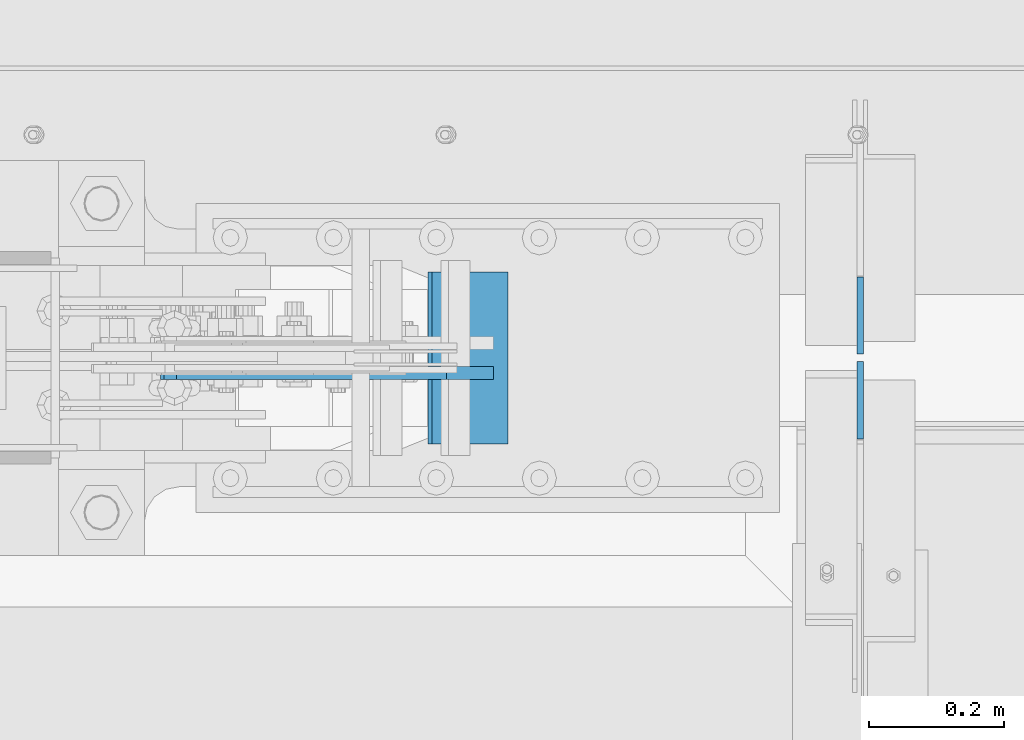
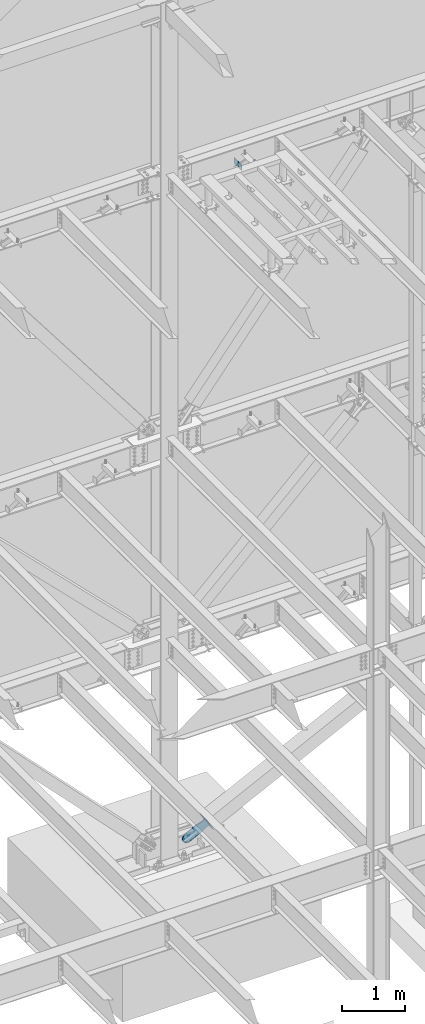
# One storey, part 1074 of 1179: 4 plates, 3 elements without a shape of their own.
"""IFC2X3 building model written with IfcOpenShell, lengths in millimetres."""

from ifc_helpers import new_model, si_unit, frame, origin_with_axes, place, context, subcontext, project, spatial, faceted_brep, material, type_object, element, aggregate, save


model = new_model("IFC2X3")

# Units and contexts
model_context = context("Model", 3, precision=1e-05, world=origin_with_axes())
body_context = subcontext(model_context, "Body", "Model", "MODEL_VIEW")
ifc_project = project(units=[si_unit("LENGTHUNIT", "METRE", prefix="MILLI"), si_unit("AREAUNIT", "SQUARE_METRE"), si_unit("VOLUMEUNIT", "CUBIC_METRE"), si_unit("MASSUNIT", "GRAM", prefix="KILO"), si_unit("TIMEUNIT", "SECOND"), si_unit("PLANEANGLEUNIT", "RADIAN"), si_unit("SOLIDANGLEUNIT", "STERADIAN"), si_unit("THERMODYNAMICTEMPERATUREUNIT", "DEGREE_CELSIUS"), si_unit("LUMINOUSINTENSITYUNIT", "LUMEN")], contexts=[model_context])

# Site, building, storey
site_placement = place(None, origin_with_axes())
site = spatial("IfcSite", under=ifc_project, at=site_placement, CompositionType="ELEMENT")
building_placement = place(site_placement, origin_with_axes())
building = spatial("IfcBuilding", under=site, at=building_placement, Name="Undefined", CompositionType="ELEMENT")
storey_placement = place(building_placement, origin_with_axes())
storey = spatial("IfcBuildingStorey", under=building, at=storey_placement, Name="Undefined", CompositionType="ELEMENT", Elevation=0.0)

# Assembly, plate
assembly_1_placement = place(storey_placement, origin_with_axes())
assembly_1 = element("IfcElementAssembly", 1, at=assembly_1_placement, inside=storey, AssemblyPlace="NOTDEFINED", PredefinedType="RIGID_FRAME")
ifc_material = material(Name="STEEL/A36")
plate_type_1 = type_object("IfcPlateType", PredefinedType="NOTDEFINED")
plate_1_placement = place(assembly_1_placement, frame((9015.15683481444, 41176.575, 58.9959651378661), z_axis=(-0.443172292794208, 0.0, 0.896436455583732), x_axis=(0.896436455583732, 0.0, 0.443172292794209)))
plate_1 = element("IfcPlate", 2, at=plate_1_placement, type_object=plate_type_1, material=ifc_material, context=body_context, shape_type="Brep", body=[
    faceted_brep([(0.0, -9.52499999999964, 0.0), (-101.599999999631, -9.52500000000146, -17.6403935121948), (-101.599999999631, 9.52500000000146, -17.6403935121948), (0.0, 9.52499999999964, 0.0), (-320.279297669141, -9.52500000000146, -17.6403935121907), (-320.279297669141, 9.52500000000146, -17.6403935121907), (-357.337405134735, -9.52500000000146, -10.2690776255863), (-357.337405134735, 9.52500000000146, -10.2690776255863), (-388.753751671267, -9.52500000000146, 10.7226540116294), (-388.753751671267, 9.52500000000146, 10.7226540116294), (-409.745483308434, -9.52500000000146, 42.1390005482076), (-409.745483308434, 9.52500000000146, 42.1390005482076), (-417.116799194993, -9.52500000000146, 79.1971049621179), (-417.116799194993, 9.52500000000146, 79.1971049621179), (-409.745483308381, -9.52500000000146, 116.255212427672), (-409.745483308381, 9.52500000000146, 116.255212427672), (-388.753751671213, -9.52500000000146, 147.671558964167), (-388.753751671213, 9.52500000000146, 147.671558964167), (-357.337405134718, -9.52500000000146, 168.663290601317), (-357.337405134718, 9.52500000000146, 168.663290601317), (-320.279299195261, -9.52500000000146, 176.034606487895), (-320.279299195261, 9.52500000000146, 176.034606487895), (-101.599999999431, -9.52500000000146, 176.034606487892), (-101.599999999431, 9.52500000000146, 176.034606487892), (2.34649633057415e-10, -9.52500000000146, 158.394212975713), (2.34649633057415e-10, 9.52500000000146, 158.394212975713), (82.5499999999411, -9.52500000000146, 158.394212975733), (82.5499999999411, 9.52500000000146, 158.394212975733), (82.5499999997119, -9.52500000000146, 1.81898940354586e-11), (82.5499999997119, 9.52500000000146, 1.81898940354586e-11)], [[[0, 1, 2, 3]], [[1, 4, 5, 2]], [[4, 6, 7, 5]], [[6, 8, 9, 7]], [[8, 10, 11, 9]], [[10, 12, 13, 11]], [[12, 14, 15, 13]], [[14, 16, 17, 15]], [[16, 18, 19, 17]], [[18, 20, 21, 19]], [[20, 22, 23, 21]], [[22, 24, 25, 23]], [[24, 26, 27, 25]], [[26, 28, 29, 27]], [[28, 0, 3, 29]], [[5, 7, 9, 11, 13, 15, 17, 19, 21, 23, 25, 27, 29, 3, 2]], [[28, 26, 24, 22, 20, 18, 16, 14, 12, 10, 8, 6, 4, 1, 0]]]),
])
aggregate(assembly_1, [plate_1])

assembly_2_placement = place(storey_placement, origin_with_axes())
assembly_2 = element("IfcElementAssembly", 3, at=assembly_2_placement, inside=storey, Name="Plate", AssemblyPlace="NOTDEFINED", PredefinedType="RIGID_FRAME")
plate_type_2 = type_object("IfcPlateType", PredefinedType="NOTDEFINED")
plate_2_placement = place(assembly_2_placement, frame((9107.49639639537, 41071.8, 51.3205094508443), z_axis=(-0.443172292794208, 0.0, 0.896436455583732), x_axis=(0.0, 1.0, 0.0)))
plate_2 = element("IfcPlate", 4, at=plate_2_placement, type_object=plate_type_2, material=ifc_material, Name="Plate", context=body_context, shape_type="Brep", body=[
    faceted_brep([(0.0, -3.17500000000109, 0.0), (0.0, -3.17499999986103, 253.99999999967), (0.0, 3.17500000013752, 253.999999999668), (0.0, 3.17500000000109, 7.27595761418343e-12), (254.0, -3.17499999986103, 253.99999999967), (254.0, 3.17500000013752, 253.999999999668), (254.0, -3.17500000000109, 9.09494701772928e-13), (254.0, 3.17499999999745, -1.36424205265939e-12)], [[[0, 1, 2, 3]], [[1, 4, 5, 2]], [[4, 6, 7, 5]], [[6, 0, 3, 7]], [[5, 7, 3, 2]], [[6, 4, 1, 0]]]),
])
aggregate(assembly_2, [plate_2])

# Assembly, plates
assembly_3_placement = place(storey_placement, origin_with_axes())
assembly_3 = element("IfcElementAssembly", 5, at=assembly_3_placement, inside=storey, Name="BEAM", AssemblyPlace="NOTDEFINED", PredefinedType="RIGID_FRAME")
plate_type_3 = type_object("IfcPlateType", PredefinedType="NOTDEFINED")
plate_3_placement = place(assembly_3_placement, frame((9631.36250000001, 41193.24375, 12690.4749987075), z_axis=(0.0, -0.707106781186506, 0.707106781186589), x_axis=(0.0, -0.70710678118659, -0.707106781186505)))
plate_3 = element("IfcPlate", 6, at=plate_3_placement, type_object=plate_type_3, material=ifc_material, Name="PLATE", context=body_context, shape_type="Brep", body=[
    faceted_brep([(0.0, -4.76249999999709, 0.0), (-67.3519210815575, -4.76250000000073, 67.3519210815502), (-67.3519210815575, 4.76250000000073, 67.3519210815502), (0.0, 4.76249999999709, 0.0), (13.4703845975746, -4.76250000000073, 148.174224853334), (13.4703845975746, 4.76250000000073, 148.174224853334), (94.2926864622132, -4.76250000000073, 67.3519210813465), (94.2926864622132, 4.76250000000073, 67.3519210813465), (26.9407683631525, -4.76249999999709, -6.18456397205591e-11), (26.9407683631525, 4.76249999999709, -6.18456397205591e-11)], [[[0, 1, 2, 3]], [[1, 4, 5, 2]], [[4, 6, 7, 5]], [[6, 8, 9, 7]], [[8, 0, 3, 9]], [[5, 7, 9, 3, 2]], [[8, 6, 4, 1, 0]]]),
])
plate_4_placement = place(assembly_3_placement, frame((9631.36250000001, 41204.35625, 12690.4749987075), z_axis=(0.0, 0.707106781186542, 0.707106781186553), x_axis=(0.0, 0.707106781186553, -0.707106781186542)))
plate_4 = element("IfcPlate", 7, at=plate_4_placement, type_object=plate_type_3, material=ifc_material, Name="PLATE", context=body_context, shape_type="Brep", body=[
    faceted_brep([(0.0, -4.76249999999709, 0.0), (-67.3519210815575, -4.76250000000073, 67.3519210815502), (-67.3519210815575, 4.76250000000073, 67.3519210815502), (0.0, 4.76249999999709, 0.0), (13.4703845975746, -4.76250000000073, 148.174224853334), (13.4703845975746, 4.76250000000073, 148.174224853334), (94.2926864622132, -4.76250000000073, 67.3519210813465), (94.2926864622132, 4.76250000000073, 67.3519210813465), (26.9407683631525, -4.76249999999709, -6.18456397205591e-11), (26.9407683631525, 4.76249999999709, -6.18456397205591e-11)], [[[0, 1, 2, 3]], [[1, 4, 5, 2]], [[4, 6, 7, 5]], [[6, 8, 9, 7]], [[8, 0, 3, 9]], [[5, 7, 9, 3, 2]], [[8, 6, 4, 1, 0]]]),
])
aggregate(assembly_3, [plate_3, plate_4])

save(model, "model.ifc")
